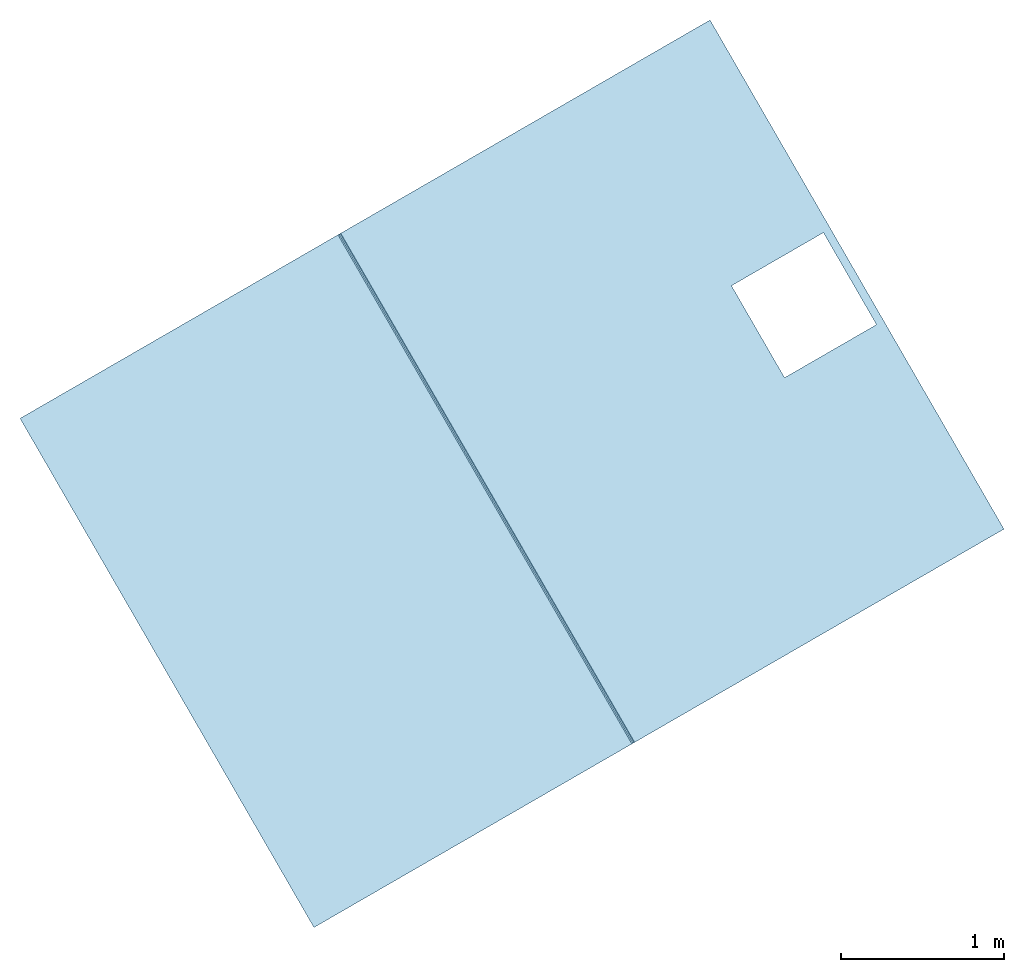
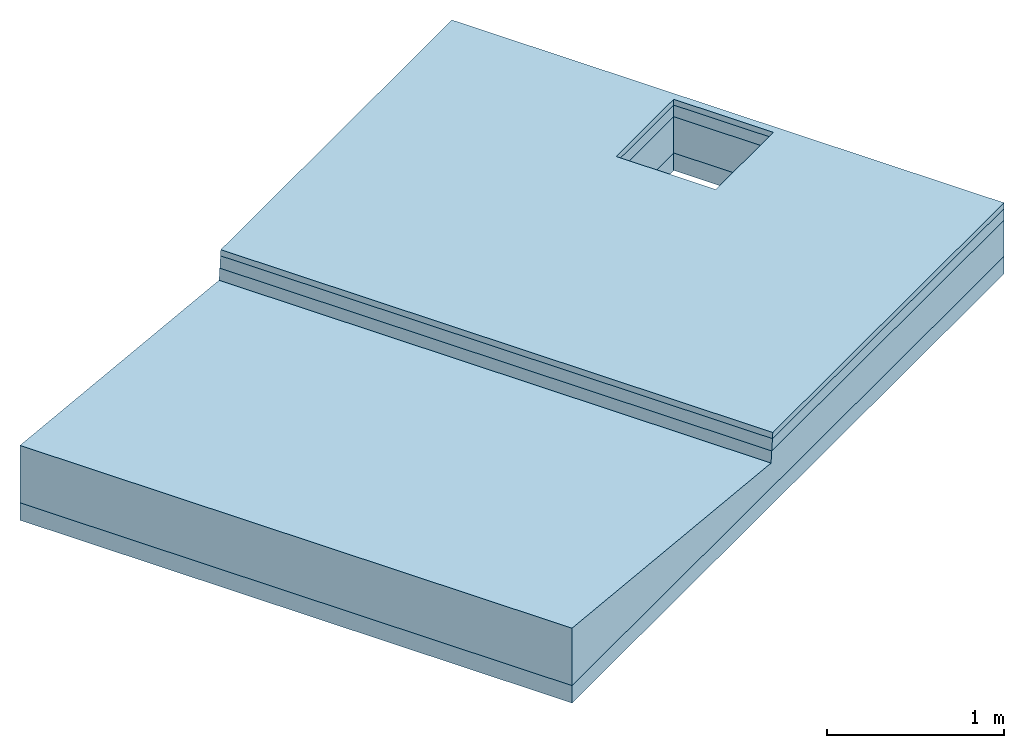
# One storey: 4 slabs.
"""IFC4 building model written with IfcOpenShell, lengths in millimetres."""

from ifc_helpers import new_model, si_unit, frame, origin_with_axes, place, context, subcontext, project, spatial, triangles, material, type_object, element, save


model = new_model("IFC4")

# Units and contexts
model_context = context("Model", 3, world=origin_with_axes())
body_context = subcontext(model_context, "Body", "Model", "MODEL_VIEW")
ifc_project = project(units=[si_unit("LENGTHUNIT", "METRE", prefix="MILLI"), si_unit("AREAUNIT", "SQUARE_METRE"), si_unit("VOLUMEUNIT", "CUBIC_METRE")], contexts=[model_context])

# Sites, buildings, storey
site_1_placement = place(None, origin_with_axes())
site_1 = spatial("IfcSite", under=ifc_project, at=site_1_placement, CompositionType="COMPLEX")
site_2_placement = place(site_1_placement, frame((17320.50807568878, 30000.000000000065, 0.0), z_axis=(0.0, 0.0, 1.0), x_axis=(-0.5000000000000003, 0.8660254037844387, 0.0)))
site_2 = spatial("IfcSite", under=site_1, at=site_2_placement, CompositionType="PARTIAL")
building_1_placement = place(site_2_placement, frame((-6.064055924070999e-11, 2.3101165425032377e-10, 2.749580119143502e-10), z_axis=(0.0, 0.0, 1.0), x_axis=(-1.0, 6.827871601444713e-15, 0.0)))
building_1 = spatial("IfcBuilding", under=site_2, at=building_1_placement, Name="bridge road connection", CompositionType="COMPLEX")
building_2_placement = place(building_1_placement, frame((-8.374172466574236e-11, 4.3314685171935707e-10, 2.6349766812927553e-11), z_axis=(-1.5815362361441076e-15, -2.9936039337702353e-15, 1.0), x_axis=(-1.0, -2.786659791809143e-14, -1.5815362361441902e-15)))
building_2 = spatial("IfcBuilding", under=building_1, at=building_2_placement, Name="bridge - road segment", CompositionType="PARTIAL")
storey_placement = place(building_2_placement, frame((0.0, 0.0, 0.0), z_axis=(0.0, 0.0, 1.0), x_axis=(1.0, 4.73449309792135e-30, 1.9721522630525295e-31)))
storey = spatial("IfcBuildingStorey", under=building_2, at=storey_placement, Name="road bridge road", CompositionType="ELEMENT", Elevation=3.0130777872727773e-10)

# Slabs
ifc_material_1 = material(Name="material_stone_generic")
slab_type_1 = type_object("IfcSlabType", Name="road base course - bridge road", PredefinedType="USERDEFINED")
slab_1_placement = place(storey_placement, frame((7.507878763135522e-11, -7560.249999996269, -1.8047785488318855e-13), z_axis=(0.0, 0.0, 1.0), x_axis=(1.0, 4.73449309792135e-30, 1.9721522630525295e-31)))
element("IfcSlab", 1, at=slab_1_placement, inside=storey, type_object=slab_type_1, material=ifc_material_1, Name="road base course - bridge road", context=body_context, shape_type="Tessellation", body=[
    triangles([(1800.0000000000155, -2439.749999995629, -489.99999999999505), (1800.0000000000184, 2439.749999995629, -369.9999999999922), (1800.000000000027, -2439.749999995641, -369.99999999999216), (1800.0000000001107, 2439.749999995635, -489.99999999974705), (-1799.999999999981, -2439.749999995629, -369.9999999999922), (-325.00000000091376, -2389.750000011413, -369.99999999999216), (-1799.999999999978, 2439.749999995641, -369.9999999999922), (1800.000000000027, -2439.749999995641, -369.99999999999216), (-325.0000000009224, -1739.7500000114162, -369.99999999999204), (324.999999999083, -2389.750000011413, -369.99999999999216), (324.999999999083, -1739.7500000114162, -369.99999999999204), (1800.0000000000184, 2439.749999995629, -369.9999999999922), (1800.000000000027, -2439.749999995641, -369.99999999999216), (-1799.999999999981, -2439.749999995629, -489.99999999999505), (1800.0000000000155, -2439.749999995629, -489.99999999999505), (-1799.999999999981, -2439.749999995629, -369.9999999999922), (-1799.999999999978, 2439.749999995641, -369.9999999999922), (1800.0000000001107, 2439.749999995635, -489.99999999974705), (-1800.0000000000819, 2439.749999995635, -489.9999999997472), (1800.0000000000184, 2439.749999995629, -369.9999999999922), (-1799.999999999978, 2439.749999995641, -369.9999999999922), (-1799.999999999981, -2439.749999995629, -489.99999999999505), (-1799.999999999981, -2439.749999995629, -369.9999999999922), (-1800.0000000000819, 2439.749999995635, -489.9999999997472), (1800.0000000001107, 2439.749999995635, -489.99999999974705), (-1799.999999999981, -2439.749999995629, -489.99999999999505), (-1800.0000000000819, 2439.749999995635, -489.9999999997472), (-325.00000000091376, -1739.7500000114162, -489.9999999999943), (-325.00000000091666, -2389.7500000114187, -489.9999999999938), (324.9999999990801, -1739.7500000114162, -489.9999999999938), (324.999999999083, -2389.7500000114187, -489.99999999999386), (1800.0000000000155, -2439.749999995629, -489.99999999999505), (-325.00000000091666, -2389.7500000114187, -489.9999999999938), (324.999999999083, -2389.750000011413, -369.99999999999216), (324.999999999083, -2389.7500000114187, -489.99999999999386), (-325.00000000091376, -2389.750000011413, -369.99999999999216), (324.999999999083, -2389.750000011413, -369.99999999999216), (324.9999999990801, -1739.7500000114162, -489.9999999999938), (324.999999999083, -2389.7500000114187, -489.99999999999386), (324.999999999083, -1739.7500000114162, -369.99999999999204), (324.9999999990801, -1739.7500000114162, -489.9999999999938), (-325.0000000009224, -1739.7500000114162, -369.99999999999204), (-325.00000000091376, -1739.7500000114162, -489.9999999999943), (324.999999999083, -1739.7500000114162, -369.99999999999204), (-325.00000000091376, -1739.7500000114162, -489.9999999999943), (-325.00000000091376, -2389.750000011413, -369.99999999999216), (-325.00000000091666, -2389.7500000114187, -489.9999999999938), (-325.0000000009224, -1739.7500000114162, -369.99999999999204)], [[1, 2, 3], [2, 1, 4], [5, 6, 7], [6, 5, 8], [7, 6, 9], [6, 8, 10], [10, 8, 11], [11, 8, 12], [9, 12, 7], [12, 9, 11], [13, 14, 15], [14, 13, 16], [17, 18, 19], [18, 17, 20], [21, 22, 23], [22, 21, 24], [25, 26, 27], [26, 25, 28], [26, 28, 29], [28, 25, 30], [30, 25, 31], [31, 25, 32], [29, 32, 26], [32, 29, 31], [33, 34, 35], [34, 33, 36], [37, 38, 39], [38, 37, 40], [41, 42, 43], [42, 41, 44], [45, 46, 47], [46, 45, 48]]),
])
ifc_material_2 = material(Name="bitumen_generic")
slab_type_2 = type_object("IfcSlabType", Name="bridge road - road asphalt course", PredefinedType="USERDEFINED")
slab_2_placement = place(storey_placement, frame((0.0, 0.0, 0.0), z_axis=(0.0, 0.0, 1.0), x_axis=(1.0, 4.73449309792135e-30, 1.9721522630525295e-31)))
element("IfcSlab", 2, at=slab_2_placement, inside=storey, type_object=slab_type_2, material=ifc_material_2, Name="bridge road - road asphalt course", ObjectType="core", context=body_context, shape_type="Tessellation", body=[
    triangles([(-1799.9999999999836, -7384.611130885973, -39.999999999995964), (1800.000000000029, -7376.611130886019, -119.99999999999653), (-1799.9999999999845, -7376.611130886021, -119.99999999999653), (1800.0000000000296, -7384.611130885971, -39.999999999995964), (-1799.9999999999836, -7384.611130885973, -39.999999999995964), (-1799.9999999999836, -10000.000000000013, -119.99999999999653), (-1799.999999999984, -10000.000000000013, -39.99999999999524), (-1799.9999999999845, -7376.611130886021, -119.99999999999653), (-1799.999999999984, -10000.000000000013, -39.99999999999524), (-325.00000000082525, -9950.000000007687, -39.99999999999583), (-1799.9999999999836, -7384.611130885973, -39.999999999995964), (1800.000000000029, -10000.000000000011, -39.99999999999524), (324.99999999917475, -9950.000000007685, -39.99999999999582), (324.99999999917975, -9300.000000007685, -39.99999999999597), (-325.0000000008204, -9300.000000007685, -39.99999999999599), (1800.0000000000296, -7384.611130885971, -39.999999999995964), (1800.000000000029, -10000.000000000011, -39.99999999999524), (-1799.9999999999836, -10000.000000000013, -119.99999999999653), (1800.0000000000296, -10000.000000000013, -119.99999999999653), (-1799.999999999984, -10000.000000000013, -39.99999999999524), (1800.000000000029, -7376.611130886019, -119.99999999999653), (-1799.9999999999836, -10000.000000000013, -119.99999999999653), (-1799.9999999999845, -7376.611130886021, -119.99999999999653), (-325.0000000008199, -9300.000000007685, -119.99999999999653), (-325.00000000082457, -9950.000000007687, -119.99999999999653), (324.99999999917554, -9300.000000007685, -119.99999999999653), (324.9999999991756, -9950.000000007685, -119.99999999999656), (1800.0000000000296, -10000.000000000013, -119.99999999999653), (1800.000000000029, -7376.611130886019, -119.99999999999653), (1800.000000000029, -10000.000000000011, -39.99999999999524), (1800.0000000000296, -10000.000000000013, -119.99999999999653), (1800.0000000000296, -7384.611130885971, -39.999999999995964), (324.99999999917975, -9300.000000007685, -39.99999999999597), (-325.0000000008199, -9300.000000007685, -119.99999999999653), (324.99999999917554, -9300.000000007685, -119.99999999999653), (-325.0000000008204, -9300.000000007685, -39.99999999999599), (-325.0000000008199, -9300.000000007685, -119.99999999999653), (-325.00000000082525, -9950.000000007687, -39.99999999999583), (-325.00000000082457, -9950.000000007687, -119.99999999999653), (-325.0000000008204, -9300.000000007685, -39.99999999999599), (-325.00000000082457, -9950.000000007687, -119.99999999999653), (324.99999999917475, -9950.000000007685, -39.99999999999582), (324.9999999991756, -9950.000000007685, -119.99999999999656), (-325.00000000082525, -9950.000000007687, -39.99999999999583), (324.99999999917975, -9300.000000007685, -39.99999999999597), (324.9999999991756, -9950.000000007685, -119.99999999999656), (324.99999999917475, -9950.000000007685, -39.99999999999582), (324.99999999917554, -9300.000000007685, -119.99999999999653)], [[1, 2, 3], [2, 1, 4], [5, 6, 7], [6, 5, 8], [9, 10, 11], [10, 9, 12], [10, 12, 13], [13, 12, 14], [11, 15, 16], [15, 11, 10], [16, 15, 14], [16, 14, 12], [17, 18, 19], [18, 17, 20], [21, 22, 23], [22, 21, 24], [22, 24, 25], [24, 21, 26], [26, 21, 27], [25, 28, 22], [28, 25, 27], [28, 27, 21], [29, 30, 31], [30, 29, 32], [33, 34, 35], [34, 33, 36], [37, 38, 39], [38, 37, 40], [41, 42, 43], [42, 41, 44], [45, 46, 47], [46, 45, 48]]),
])
ifc_material_3 = material(Name="material_gravel_generic")
slab_type_3 = type_object("IfcSlabType", Name="road bridge road", PredefinedType="USERDEFINED")
slab_3_placement = place(storey_placement, frame((0.0, 0.0, 0.0), z_axis=(0.0, 0.0, 1.0), x_axis=(1.0, 4.73449309792135e-30, 1.9721522630525295e-31)))
element("IfcSlab", 3, at=slab_3_placement, inside=storey, type_object=slab_type_3, material=ifc_material_3, Name="road bridge road", context=body_context, shape_type="Tessellation", body=[
    triangles([(1800.0000000000125, -5120.500000000178, -369.9999999999924), (1800.0000000000184, -10000.000000000036, -119.99999999999577), (1800.0000000000125, -10000.000000000036, -369.9999999999924), (1800.0000000000068, -7368.71038708181, -199.0074380419954), (1800.0000000000125, -7376.611130886026, -119.99999999999574), (1800.0000000000125, -5120.500000000213, 25.81360066616533), (1800.0000000000184, -5120.500000000166, -119.9999999999958), (-1799.999999999981, -5120.500000000161, -119.99999999999577), (1800.0000000000125, -5120.500000000178, -369.9999999999924), (-1799.9999999999836, -5120.500000000161, -369.9999999999924), (1800.0000000000184, -5120.500000000166, -119.9999999999958), (1800.0000000000125, -5120.500000000213, 25.81360066616533), (-1799.9999999999895, -5120.500000000207, 25.813600666093855), (-1799.9999999999952, -7376.611130886021, -119.9999999998644), (-1799.9999999999895, -10000.000000000036, -369.9999999999924), (-1799.9999999999895, -10000.000000000036, -119.9999999999958), (-1799.9999999999952, -7368.710387081816, -199.00743804186402), (-1799.9999999999836, -5120.500000000161, -369.9999999999924), (-1799.9999999999895, -5120.500000000207, 25.813600666093855), (-1799.999999999981, -5120.500000000161, -119.99999999999577), (1800.0000000000184, -10000.000000000036, -119.99999999999577), (-325.00000000083, -9950.000000007687, -119.99999999997891), (-1799.9999999999895, -10000.000000000036, -119.9999999999958), (324.9999999991754, -9950.000000007682, -119.9999999999908), (324.9999999991754, -9300.00000000769, -119.9999999999771), (1800.0000000000125, -7376.611130886026, -119.99999999999574), (-1799.9999999999952, -7376.611130886021, -119.9999999998644), (-325.00000000082713, -9300.00000000769, -119.99999999996528), (-1799.9999999999952, -7368.710387081816, -199.00743804186402), (1800.0000000000125, -7376.611130886026, -119.99999999999574), (1800.0000000000068, -7368.71038708181, -199.0074380419954), (-1799.9999999999952, -7376.611130886021, -119.9999999998644), (1800.0000000000068, -7368.71038708181, -199.0074380419954), (-1799.9999999999895, -5120.500000000207, 25.813600666093855), (-1799.9999999999952, -7368.710387081816, -199.00743804186402), (1800.0000000000125, -5120.500000000213, 25.81360066616533), (1800.0000000000184, -10000.000000000036, -119.99999999999577), (-1799.9999999999895, -10000.000000000036, -369.9999999999924), (1800.0000000000125, -10000.000000000036, -369.9999999999924), (-1799.9999999999895, -10000.000000000036, -119.9999999999958), (1800.0000000000125, -5120.500000000178, -369.9999999999924), (-325.00000000082713, -9300.000000007685, -369.9999999999924), (-1799.9999999999836, -5120.500000000161, -369.9999999999924), (324.99999999916963, -9300.000000007685, -369.9999999999924), (324.99999999917827, -9950.000000007682, -369.9999999999924), (-1799.9999999999895, -10000.000000000036, -369.9999999999924), (-325.00000000082133, -9950.000000007687, -369.9999999999924), (1800.0000000000125, -10000.000000000036, -369.9999999999924), (324.9999999991754, -9300.00000000769, -119.9999999999771), (-325.00000000082713, -9300.000000007685, -369.9999999999924), (324.99999999916963, -9300.000000007685, -369.9999999999924), (-325.00000000082713, -9300.00000000769, -119.99999999996528), (-325.00000000082713, -9300.000000007685, -369.9999999999924), (-325.00000000083, -9950.000000007687, -119.99999999997891), (-325.00000000082133, -9950.000000007687, -369.9999999999924), (-325.00000000082713, -9300.00000000769, -119.99999999996528), (-325.00000000083, -9950.000000007687, -119.99999999997891), (324.99999999917827, -9950.000000007682, -369.9999999999924), (-325.00000000082133, -9950.000000007687, -369.9999999999924), (324.9999999991754, -9950.000000007682, -119.9999999999908), (324.9999999991754, -9300.00000000769, -119.9999999999771), (324.99999999917827, -9950.000000007682, -369.9999999999924), (324.9999999991754, -9950.000000007682, -119.9999999999908), (324.99999999916963, -9300.000000007685, -369.9999999999924)], [[1, 2, 3], [2, 1, 4], [2, 4, 5], [4, 1, 6], [6, 1, 7], [8, 9, 10], [9, 8, 11], [11, 8, 12], [12, 8, 13], [14, 15, 16], [15, 14, 17], [15, 17, 18], [18, 17, 19], [18, 19, 20], [21, 22, 23], [22, 21, 24], [24, 21, 25], [25, 21, 26], [23, 26, 27], [26, 23, 28], [28, 23, 22], [26, 28, 25], [29, 30, 31], [30, 29, 32], [33, 34, 35], [34, 33, 36], [37, 38, 39], [38, 37, 40], [41, 42, 43], [42, 41, 44], [44, 41, 45], [46, 47, 48], [47, 46, 43], [47, 43, 42], [48, 47, 45], [48, 45, 41], [49, 50, 51], [50, 49, 52], [53, 54, 55], [54, 53, 56], [57, 58, 59], [58, 57, 60], [61, 62, 63], [62, 61, 64]]),
])
ifc_material_4 = material(Name="bitumen_asphalt_generic")
slab_type_4 = type_object("IfcSlabType", Name="road asphalt surface course - bridge road", PredefinedType="USERDEFINED")
slab_4_placement = place(storey_placement, frame((0.0, 0.0, 0.0), z_axis=(0.0, 0.0, 1.0), x_axis=(1.0, 4.73449309792135e-30, 1.9721522630525295e-31)))
element("IfcSlab", 4, at=slab_4_placement, inside=storey, type_object=slab_type_4, material=ifc_material_4, Name="road asphalt surface course - bridge road", ObjectType="pavement", context=body_context, shape_type="Tessellation", body=[
    triangles([(-1799.9999999999723, -7388.611130885949, 4.334111182094726e-12), (1800.000000000024, -7384.611130885973, -39.99999999999596), (-1799.9999999999866, -7384.611130885973, -39.99999999999597), (1800.000000000024, -7388.6111308859545, 4.331309337467076e-12), (1800.000000000024, -7384.611130885973, -39.99999999999596), (1800.0000000000327, -10000.000000000013, 4.330792435906303e-12), (1800.0000000000327, -10000.000000000013, -39.99999999999596), (1800.000000000024, -7388.6111308859545, 4.331309337467076e-12), (-1799.9999999999866, -7384.611130885973, -39.99999999999597), (-325.00000000082423, -9300.00000000768, -39.999999999995964), (-325.00000000083287, -9950.000000007682, -39.999999999995964), (1800.000000000024, -7384.611130885973, -39.99999999999596), (324.99999999916383, -9300.000000007685, -39.99999999999595), (324.9999999991754, -9950.000000007687, -39.99999999999595), (-1799.9999999999923, -10000.000000000013, -39.99999999999594), (1800.0000000000327, -10000.000000000013, -39.99999999999596), (1800.0000000000327, -10000.000000000013, 4.330792435906303e-12), (-1799.9999999999923, -10000.000000000013, -39.99999999999594), (1800.0000000000327, -10000.000000000013, -39.99999999999596), (-1799.9999999999923, -10000.000000000013, 4.333594280533994e-12), (-1799.9999999999923, -10000.000000000013, 4.333594280533994e-12), (-325.00000000081843, -9950.000000007682, 4.334469920868654e-12), (-1799.9999999999723, -7388.611130885949, 4.334111182094726e-12), (1800.0000000000327, -10000.000000000013, 4.330792435906303e-12), (-325.00000000082423, -9300.00000000768, 4.334535604861217e-12), (324.9999999991754, -9950.000000007687, 4.3472805406451894e-12), (1800.000000000024, -7388.6111308859545, 4.331309337467076e-12), (324.99999999916383, -9300.000000007685, 4.3473462246377525e-12), (-1799.9999999999723, -7388.611130885949, 4.334111182094726e-12), (-1799.9999999999923, -10000.000000000013, -39.99999999999594), (-1799.9999999999923, -10000.000000000013, 4.333594280533994e-12), (-1799.9999999999866, -7384.611130885973, -39.99999999999597), (-325.00000000081843, -9950.000000007682, 4.334469920868654e-12), (324.9999999991754, -9950.000000007687, -39.99999999999595), (-325.00000000083287, -9950.000000007682, -39.999999999995964), (324.9999999991754, -9950.000000007687, 4.3472805406451894e-12), (-325.00000000082423, -9300.00000000768, -39.999999999995964), (-325.00000000081843, -9950.000000007682, 4.334469920868654e-12), (-325.00000000083287, -9950.000000007682, -39.999999999995964), (-325.00000000082423, -9300.00000000768, 4.334535604861217e-12), (324.99999999916383, -9300.000000007685, 4.3473462246377525e-12), (324.9999999991754, -9950.000000007687, -39.99999999999595), (324.9999999991754, -9950.000000007687, 4.3472805406451894e-12), (324.99999999916383, -9300.000000007685, -39.99999999999595), (324.99999999916383, -9300.000000007685, -39.99999999999595), (-325.00000000082423, -9300.00000000768, 4.334535604861217e-12), (-325.00000000082423, -9300.00000000768, -39.999999999995964), (324.99999999916383, -9300.000000007685, 4.3473462246377525e-12)], [[1, 2, 3], [2, 1, 4], [5, 6, 7], [6, 5, 8], [9, 10, 11], [10, 9, 12], [10, 12, 13], [13, 12, 14], [15, 11, 16], [11, 15, 9], [16, 11, 14], [16, 14, 12], [17, 18, 19], [18, 17, 20], [21, 22, 23], [22, 21, 24], [23, 22, 25], [22, 24, 26], [26, 24, 27], [25, 27, 23], [27, 25, 28], [27, 28, 26], [29, 30, 31], [30, 29, 32], [33, 34, 35], [34, 33, 36], [37, 38, 39], [38, 37, 40], [41, 42, 43], [42, 41, 44], [45, 46, 47], [46, 45, 48]]),
])

save(model, "model.ifc")
